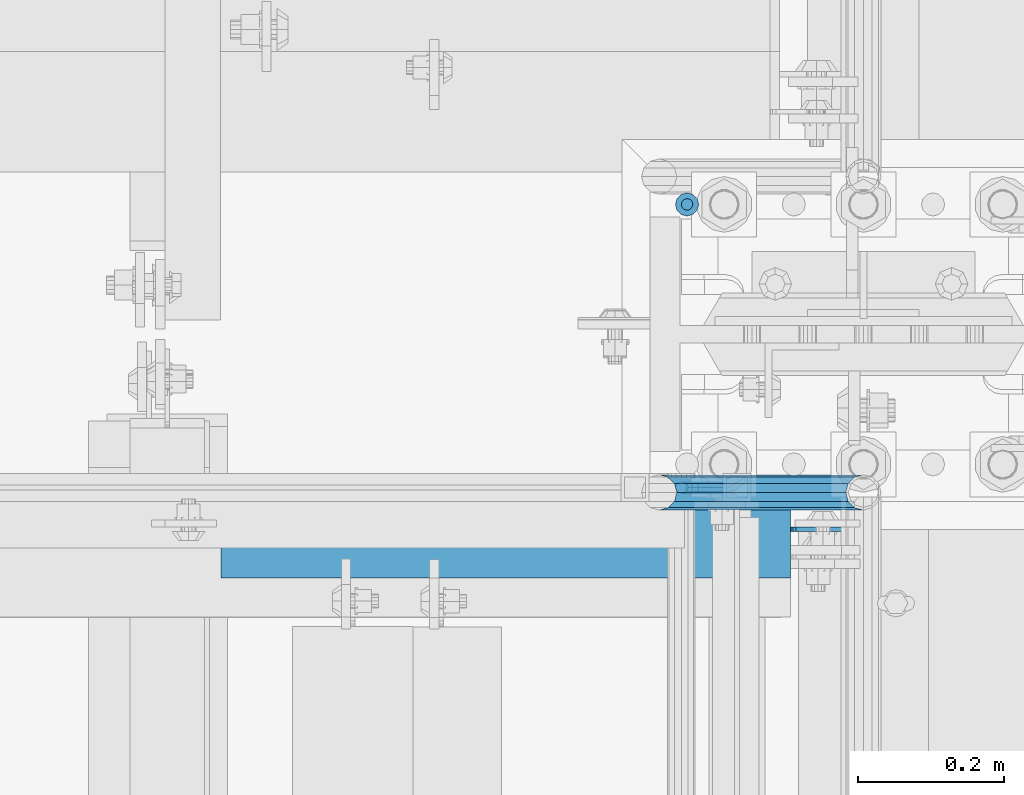
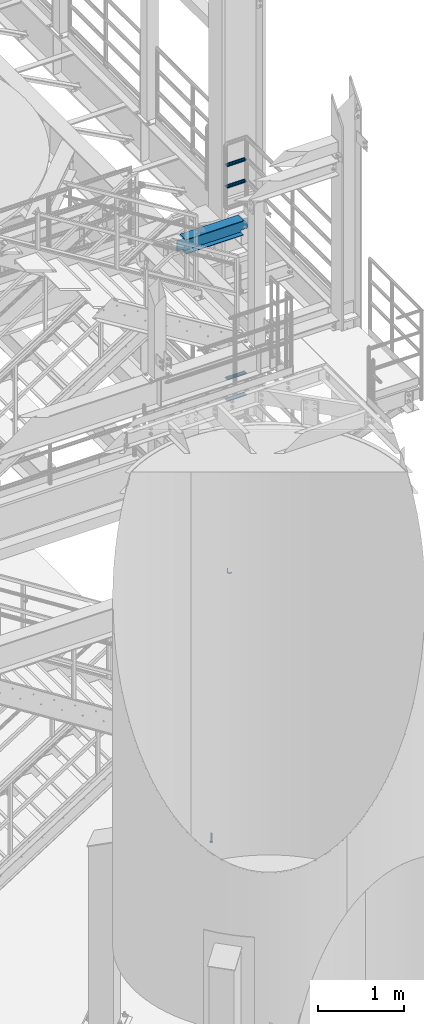
# One storey, part 1210 of 1876: 7 beams, 5 elements without a shape of their own.
"""IFC2X3 building model written with IfcOpenShell, lengths in millimetres."""

from ifc_helpers import new_model, si_unit, frame, origin_with_axes, place, context, subcontext, project, spatial, faceted_brep, material, type_object, element, aggregate, save


model = new_model("IFC2X3")

# Units and contexts
model_context = context("Model", 3, precision=1e-05, world=origin_with_axes())
body_context = subcontext(model_context, "Body", "Model", "MODEL_VIEW")
ifc_project = project(units=[si_unit("LENGTHUNIT", "METRE", prefix="MILLI"), si_unit("AREAUNIT", "SQUARE_METRE"), si_unit("VOLUMEUNIT", "CUBIC_METRE"), si_unit("MASSUNIT", "GRAM", prefix="KILO"), si_unit("TIMEUNIT", "SECOND"), si_unit("PLANEANGLEUNIT", "RADIAN"), si_unit("SOLIDANGLEUNIT", "STERADIAN"), si_unit("THERMODYNAMICTEMPERATUREUNIT", "DEGREE_CELSIUS"), si_unit("LUMINOUSINTENSITYUNIT", "LUMEN")], contexts=[model_context])

# Site, building, storey
site_placement = place(None, origin_with_axes())
site = spatial("IfcSite", under=ifc_project, at=site_placement, CompositionType="ELEMENT")
building_placement = place(site_placement, origin_with_axes())
building = spatial("IfcBuilding", under=site, at=building_placement, Name="Undefined", CompositionType="ELEMENT")
storey_placement = place(building_placement, origin_with_axes())
storey = spatial("IfcBuildingStorey", under=building, at=storey_placement, Name="Undefined", CompositionType="ELEMENT", Elevation=0.0)

# Assembly, beams
assembly_1_placement = place(storey_placement, origin_with_axes())
assembly_1 = element("IfcElementAssembly", 1, at=assembly_1_placement, inside=storey, Name="RAIL", AssemblyPlace="NOTDEFINED", PredefinedType="RIGID_FRAME")
ifc_material_1 = material()
beam_type_1 = type_object("IfcBeamType", Name="PIPE1-1/2SCH40", PredefinedType="NOTDEFINED")
beam_1_placement = place(assembly_1_placement, frame((7620.0, -4788.2175, 8620.125000036), z_axis=(0.0, 0.0, 1.0), x_axis=(-1.0, 0.0, 0.0)))
beam_1 = element("IfcBeam", 2, at=beam_1_placement, type_object=beam_type_1, material=ifc_material_1, Name="RAIL", ObjectType="PIPE1-1/2SCH40", context=body_context, shape_type="Brep", body=[
    faceted_brep([(258.502800903171, -12.0650000000005, 20.8971929933177), (258.502800903171, -12.0650000000005, 15.8661214311796), (258.009372465309, -10.2235000000001, 17.7076214311819), (255.26999389649, 0.0, 20.4470000000001), (255.26999389649, 0.0, 24.130000000001), (258.009372465309, 10.2235000000001, 17.7076214311819), (258.502800903171, 12.0650000000005, 15.8661214311796), (258.502800903171, 12.0650000000005, 20.8971929933177), (279.399993896489, 24.1299999999992, 0.0), (267.33499389649, 20.8971929933177, 12.0649999999987), (267.33499389649, 20.8971929933177, -12.0649999999987), (264.145422334351, 17.7076214311801, 10.2235000000001), (266.884800903171, 20.4470000000001, 0.0), (264.145422334351, 17.7076214311801, -10.2235000000001), (258.502800903171, 12.0650000000005, -15.8661214311796), (258.502800903171, 12.0650000000005, -20.8971929933177), (258.009372465309, 10.2235000000001, -17.7076214311819), (255.26999389649, 0.0, -20.4470000000001), (255.26999389649, 0.0, -24.130000000001), (258.502800903171, -12.0650000000005, -15.8661214311796), (258.502800903171, -12.0650000000005, -20.8971929933177), (258.009372465309, -10.2235000000001, -17.7076214311819), (279.399993896489, -24.1299999999992, 0.0), (267.33499389649, -20.8971929933177, -12.0649999999987), (267.33499389649, -20.8971929933177, 12.0649999999987), (264.145422334351, -17.7076214311801, -10.2235000000001), (266.884800903171, -20.4470000000001, 0.0), (264.145422334351, -17.7076214311801, 10.2235000000001), (12.0650000000064, -20.8971929933177, -12.0649999999987), (20.8971929933249, -12.0650000000005, -20.8971929933177), (0.0, 24.1299999999992, 0.0), (12.0650000000064, 20.8971929933177, -12.0649999999987), (12.0650000000064, 20.8971929933177, 12.0649999999987), (20.8971929933249, 12.0650000000005, 20.8971929933177), (24.1300000000064, 0.0, 24.130000000001), (20.8971929933249, 12.0650000000005, -20.8971929933177), (24.1300000000063, 0.0, -24.130000000001), (24.1300000000063, 0.0, -20.4470000000001), (20.8971929933249, -12.0650000000005, -15.8661214311796), (21.3906214311868, -10.2235000000001, -17.7076214311819), (21.3906214311868, 10.2235000000001, -17.7076214311819), (20.8971929933249, 12.0650000000005, -15.8661214311796), (15.2545715621445, 17.7076214311801, -10.2235000000001), (12.5151929933249, 20.4470000000001, 0.0), (15.2545715621445, 17.7076214311801, 10.2235000000001), (20.8971929933249, 12.0650000000005, 15.8661214311796), (21.3906214311868, 10.2235000000001, 17.7076214311819), (24.1300000000064, 0.0, 20.4470000000001), (21.3906214311868, -10.2235000000001, 17.7076214311819), (20.8971929933249, -12.0650000000005, 15.8661214311796), (20.8971929933249, -12.0650000000005, 20.8971929933177), (12.0650000000064, -20.8971929933177, 12.0649999999987), (0.0, -24.1299999999992, 0.0), (15.2545715621445, -17.7076214311801, 10.2235000000001), (12.5151929933249, -20.4470000000001, 0.0), (15.2545715621445, -17.7076214311801, -10.2235000000001)], [[[0, 1, 2, 3, 4]], [[4, 3, 5, 6, 7]], [[8, 9, 10]], [[7, 6, 11, 12, 13, 14, 15, 10, 9]], [[16, 17, 18, 15, 14]], [[19, 20, 18, 17, 21]], [[22, 23, 24]], [[24, 23, 20, 19, 25, 26, 27, 1, 0]], [[28, 29, 20, 23]], [[30, 31, 32]], [[33, 34, 4, 7]], [[32, 33, 7, 9]], [[30, 32, 9, 8]], [[31, 30, 8, 10]], [[35, 31, 10, 15]], [[36, 35, 15, 18]], [[29, 36, 18, 20]], [[37, 36, 29, 38, 39]], [[40, 41, 35, 36, 37]], [[32, 31, 35, 41, 42, 43, 44, 45, 33]], [[33, 45, 46, 47, 34]], [[34, 47, 48, 49, 50]], [[34, 50, 0, 4]], [[50, 51, 24, 0]], [[51, 52, 22, 24]], [[52, 28, 23, 22]], [[51, 28, 52]], [[50, 49, 53, 54, 55, 38, 29, 28, 51]], [[55, 54, 26, 25]], [[21, 39, 38, 55, 25, 19]], [[37, 39, 21, 17]], [[40, 37, 17, 16]], [[42, 41, 40, 16, 14, 13]], [[43, 42, 13, 12]], [[44, 43, 12, 11]], [[5, 46, 45, 44, 11, 6]], [[47, 46, 5, 3]], [[48, 47, 3, 2]], [[53, 49, 48, 2, 1, 27]], [[54, 53, 27, 26]]]),
])
beam_2_placement = place(assembly_1_placement, frame((7620.0, -4788.2175, 8924.92500003594), z_axis=(0.0, 0.0, 1.0), x_axis=(-1.0, 0.0, 0.0)))
beam_2 = element("IfcBeam", 3, at=beam_2_placement, type_object=beam_type_1, material=ifc_material_1, Name="RAIL", ObjectType="PIPE1-1/2SCH40", context=body_context, shape_type="Brep", body=[
    faceted_brep([(258.502800903171, -12.0650000000005, 20.8971929933177), (258.502800903171, -12.0650000000005, 15.8661214311796), (258.009372465309, -10.2235000000001, 17.7076214311819), (255.26999389649, 0.0, 20.4470000000001), (255.26999389649, 0.0, 24.130000000001), (258.009372465309, 10.2235000000001, 17.7076214311819), (258.502800903171, 12.0650000000005, 15.8661214311796), (258.502800903171, 12.0650000000005, 20.8971929933177), (279.399993896489, 24.1299999999992, 0.0), (267.33499389649, 20.8971929933177, 12.0649999999987), (267.33499389649, 20.8971929933177, -12.0649999999987), (264.145422334351, 17.7076214311801, 10.2235000000001), (266.884800903171, 20.4470000000001, 0.0), (264.145422334351, 17.7076214311801, -10.2235000000001), (258.502800903171, 12.0650000000005, -15.8661214311796), (258.502800903171, 12.0650000000005, -20.8971929933177), (258.009372465309, 10.2235000000001, -17.7076214311819), (255.26999389649, 0.0, -20.4470000000001), (255.26999389649, 0.0, -24.130000000001), (258.502800903171, -12.0650000000005, -15.8661214311796), (258.502800903171, -12.0650000000005, -20.8971929933177), (258.009372465309, -10.2235000000001, -17.7076214311819), (279.399993896489, -24.1299999999992, 0.0), (267.33499389649, -20.8971929933177, -12.0649999999987), (267.33499389649, -20.8971929933177, 12.0649999999987), (264.145422334351, -17.7076214311801, -10.2235000000001), (266.884800903171, -20.4470000000001, 0.0), (264.145422334351, -17.7076214311801, 10.2235000000001), (12.0650000000064, -20.8971929933177, -12.0649999999987), (20.8971929933249, -12.0650000000005, -20.8971929933177), (0.0, 24.1299999999992, 0.0), (12.0650000000064, 20.8971929933177, -12.0649999999987), (12.0650000000064, 20.8971929933177, 12.0649999999987), (20.8971929933249, 12.0650000000005, 20.8971929933177), (24.1300000000064, 0.0, 24.130000000001), (20.8971929933249, 12.0650000000005, -20.8971929933177), (24.1300000000063, 0.0, -24.130000000001), (24.1300000000063, 0.0, -20.4470000000001), (20.8971929933249, -12.0650000000005, -15.8661214311796), (21.3906214311868, -10.2235000000001, -17.7076214311819), (21.3906214311868, 10.2235000000001, -17.7076214311819), (20.8971929933249, 12.0650000000005, -15.8661214311796), (15.2545715621445, 17.7076214311801, -10.2235000000001), (12.5151929933249, 20.4470000000001, 0.0), (15.2545715621445, 17.7076214311801, 10.2235000000001), (20.8971929933249, 12.0650000000005, 15.8661214311796), (21.3906214311868, 10.2235000000001, 17.7076214311819), (24.1300000000064, 0.0, 20.4470000000001), (21.3906214311868, -10.2235000000001, 17.7076214311819), (20.8971929933249, -12.0650000000005, 15.8661214311796), (20.8971929933249, -12.0650000000005, 20.8971929933177), (12.0650000000064, -20.8971929933177, 12.0649999999987), (0.0, -24.1299999999992, 0.0), (15.2545715621445, -17.7076214311801, 10.2235000000001), (12.5151929933249, -20.4470000000001, 0.0), (15.2545715621445, -17.7076214311801, -10.2235000000001)], [[[0, 1, 2, 3, 4]], [[4, 3, 5, 6, 7]], [[8, 9, 10]], [[7, 6, 11, 12, 13, 14, 15, 10, 9]], [[16, 17, 18, 15, 14]], [[19, 20, 18, 17, 21]], [[22, 23, 24]], [[24, 23, 20, 19, 25, 26, 27, 1, 0]], [[28, 29, 20, 23]], [[30, 31, 32]], [[33, 34, 4, 7]], [[32, 33, 7, 9]], [[30, 32, 9, 8]], [[31, 30, 8, 10]], [[35, 31, 10, 15]], [[36, 35, 15, 18]], [[29, 36, 18, 20]], [[37, 36, 29, 38, 39]], [[40, 41, 35, 36, 37]], [[32, 31, 35, 41, 42, 43, 44, 45, 33]], [[33, 45, 46, 47, 34]], [[34, 47, 48, 49, 50]], [[34, 50, 0, 4]], [[50, 51, 24, 0]], [[51, 52, 22, 24]], [[52, 28, 23, 22]], [[51, 28, 52]], [[50, 49, 53, 54, 55, 38, 29, 28, 51]], [[55, 54, 26, 25]], [[21, 39, 38, 55, 25, 19]], [[37, 39, 21, 17]], [[40, 37, 17, 16]], [[42, 41, 40, 16, 14, 13]], [[43, 42, 13, 12]], [[44, 43, 12, 11]], [[5, 46, 45, 44, 11, 6]], [[47, 46, 5, 3]], [[48, 47, 3, 2]], [[53, 49, 48, 2, 1, 27]], [[54, 53, 27, 26]]]),
])
aggregate(assembly_1, [beam_1, beam_2])

assembly_2_placement = place(storey_placement, origin_with_axes())
assembly_2 = element("IfcElementAssembly", 4, at=assembly_2_placement, inside=storey, Name="RAIL", AssemblyPlace="NOTDEFINED", PredefinedType="RIGID_FRAME")
beam_3_placement = place(assembly_2_placement, frame((7620.0, -4788.2175, 5597.525000036), z_axis=(0.0, 0.0, 1.0), x_axis=(-1.0, 0.0, 0.0)))
beam_3 = element("IfcBeam", 5, at=beam_3_placement, type_object=beam_type_1, material=ifc_material_1, Name="RAIL", ObjectType="PIPE1-1/2SCH40", context=body_context, shape_type="Brep", body=[
    faceted_brep([(258.502800903171, -12.0650000000005, 20.8971929933177), (258.502800903171, -12.0650000000005, 15.8661214311796), (258.009372465309, -10.2235000000001, 17.7076214311819), (255.26999389649, 0.0, 20.4470000000001), (255.26999389649, 0.0, 24.130000000001), (258.009372465309, 10.2235000000001, 17.7076214311819), (258.502800903171, 12.0650000000005, 15.8661214311796), (258.502800903171, 12.0650000000005, 20.8971929933177), (279.399993896489, 24.1299999999992, 0.0), (267.33499389649, 20.8971929933177, 12.0649999999987), (267.33499389649, 20.8971929933177, -12.0649999999987), (264.145422334351, 17.7076214311801, 10.2235000000001), (266.884800903171, 20.4470000000001, 0.0), (264.145422334351, 17.7076214311801, -10.2235000000001), (258.502800903171, 12.0650000000005, -15.8661214311796), (258.502800903171, 12.0650000000005, -20.8971929933177), (258.009372465309, 10.2235000000001, -17.7076214311819), (255.26999389649, 0.0, -20.4470000000001), (255.26999389649, 0.0, -24.130000000001), (258.502800903171, -12.0650000000005, -15.8661214311796), (258.502800903171, -12.0650000000005, -20.8971929933177), (258.009372465309, -10.2235000000001, -17.7076214311819), (279.399993896489, -24.1299999999992, 0.0), (267.33499389649, -20.8971929933177, -12.0649999999987), (267.33499389649, -20.8971929933177, 12.0649999999987), (264.145422334351, -17.7076214311801, -10.2235000000001), (266.884800903171, -20.4470000000001, 0.0), (264.145422334351, -17.7076214311801, 10.2235000000001), (12.0650000000064, -20.8971929933177, -12.0649999999987), (20.8971929933249, -12.0650000000005, -20.8971929933177), (0.0, 24.1299999999992, 0.0), (12.0650000000064, 20.8971929933177, -12.0649999999987), (12.0650000000064, 20.8971929933177, 12.0649999999987), (20.8971929933249, 12.0650000000005, 20.8971929933177), (24.1300000000064, 0.0, 24.130000000001), (20.8971929933249, 12.0650000000005, -20.8971929933177), (24.1300000000063, 0.0, -24.130000000001), (24.1300000000063, 0.0, -20.4470000000001), (20.8971929933249, -12.0650000000005, -15.8661214311796), (21.3906214311868, -10.2235000000001, -17.7076214311819), (21.3906214311868, 10.2235000000001, -17.7076214311819), (20.8971929933249, 12.0650000000005, -15.8661214311796), (15.2545715621445, 17.7076214311801, -10.2235000000001), (12.5151929933249, 20.4470000000001, 0.0), (15.2545715621445, 17.7076214311801, 10.2235000000001), (20.8971929933249, 12.0650000000005, 15.8661214311796), (21.3906214311868, 10.2235000000001, 17.7076214311819), (24.1300000000064, 0.0, 20.4470000000001), (21.3906214311868, -10.2235000000001, 17.7076214311819), (20.8971929933249, -12.0650000000005, 15.8661214311796), (20.8971929933249, -12.0650000000005, 20.8971929933177), (12.0650000000064, -20.8971929933177, 12.0649999999987), (0.0, -24.1299999999992, 0.0), (15.2545715621445, -17.7076214311801, 10.2235000000001), (12.5151929933249, -20.4470000000001, 0.0), (15.2545715621445, -17.7076214311801, -10.2235000000001)], [[[0, 1, 2, 3, 4]], [[4, 3, 5, 6, 7]], [[8, 9, 10]], [[7, 6, 11, 12, 13, 14, 15, 10, 9]], [[16, 17, 18, 15, 14]], [[19, 20, 18, 17, 21]], [[22, 23, 24]], [[24, 23, 20, 19, 25, 26, 27, 1, 0]], [[28, 29, 20, 23]], [[30, 31, 32]], [[33, 34, 4, 7]], [[32, 33, 7, 9]], [[30, 32, 9, 8]], [[31, 30, 8, 10]], [[35, 31, 10, 15]], [[36, 35, 15, 18]], [[29, 36, 18, 20]], [[37, 36, 29, 38, 39]], [[40, 41, 35, 36, 37]], [[32, 31, 35, 41, 42, 43, 44, 45, 33]], [[33, 45, 46, 47, 34]], [[34, 47, 48, 49, 50]], [[34, 50, 0, 4]], [[50, 51, 24, 0]], [[51, 52, 22, 24]], [[52, 28, 23, 22]], [[51, 28, 52]], [[50, 49, 53, 54, 55, 38, 29, 28, 51]], [[55, 54, 26, 25]], [[21, 39, 38, 55, 25, 19]], [[37, 39, 21, 17]], [[40, 37, 17, 16]], [[42, 41, 40, 16, 14, 13]], [[43, 42, 13, 12]], [[44, 43, 12, 11]], [[5, 46, 45, 44, 11, 6]], [[47, 46, 5, 3]], [[48, 47, 3, 2]], [[53, 49, 48, 2, 1, 27]], [[54, 53, 27, 26]]]),
])
beam_4_placement = place(assembly_2_placement, frame((7620.0, -4788.2175, 5902.32500003594), z_axis=(0.0, 0.0, 1.0), x_axis=(-1.0, 0.0, 0.0)))
beam_4 = element("IfcBeam", 6, at=beam_4_placement, type_object=beam_type_1, material=ifc_material_1, Name="RAIL", ObjectType="PIPE1-1/2SCH40", context=body_context, shape_type="Brep", body=[
    faceted_brep([(258.502800903171, -12.0650000000005, 20.8971929933177), (258.502800903171, -12.0650000000005, 15.8661214311796), (258.009372465309, -10.2235000000001, 17.7076214311819), (255.26999389649, 0.0, 20.4470000000001), (255.26999389649, 0.0, 24.130000000001), (258.009372465309, 10.2235000000001, 17.7076214311819), (258.502800903171, 12.0650000000005, 15.8661214311796), (258.502800903171, 12.0650000000005, 20.8971929933177), (279.399993896489, 24.1299999999992, 0.0), (267.33499389649, 20.8971929933177, 12.0649999999987), (267.33499389649, 20.8971929933177, -12.0649999999987), (264.145422334351, 17.7076214311801, 10.2235000000001), (266.884800903171, 20.4470000000001, 0.0), (264.145422334351, 17.7076214311801, -10.2235000000001), (258.502800903171, 12.0650000000005, -15.8661214311796), (258.502800903171, 12.0650000000005, -20.8971929933177), (258.009372465309, 10.2235000000001, -17.7076214311819), (255.26999389649, 0.0, -20.4470000000001), (255.26999389649, 0.0, -24.130000000001), (258.502800903171, -12.0650000000005, -15.8661214311796), (258.502800903171, -12.0650000000005, -20.8971929933177), (258.009372465309, -10.2235000000001, -17.7076214311819), (279.399993896489, -24.1299999999992, 0.0), (267.33499389649, -20.8971929933177, -12.0649999999987), (267.33499389649, -20.8971929933177, 12.0649999999987), (264.145422334351, -17.7076214311801, -10.2235000000001), (266.884800903171, -20.4470000000001, 0.0), (264.145422334351, -17.7076214311801, 10.2235000000001), (12.0650000000064, -20.8971929933177, -12.0649999999987), (20.8971929933249, -12.0650000000005, -20.8971929933177), (0.0, 24.1299999999992, 0.0), (12.0650000000064, 20.8971929933177, -12.0649999999987), (12.0650000000064, 20.8971929933177, 12.0649999999987), (20.8971929933249, 12.0650000000005, 20.8971929933177), (24.1300000000064, 0.0, 24.130000000001), (20.8971929933249, 12.0650000000005, -20.8971929933177), (24.1300000000063, 0.0, -24.130000000001), (24.1300000000063, 0.0, -20.4470000000001), (20.8971929933249, -12.0650000000005, -15.8661214311796), (21.3906214311868, -10.2235000000001, -17.7076214311819), (21.3906214311868, 10.2235000000001, -17.7076214311819), (20.8971929933249, 12.0650000000005, -15.8661214311796), (15.2545715621445, 17.7076214311801, -10.2235000000001), (12.5151929933249, 20.4470000000001, 0.0), (15.2545715621445, 17.7076214311801, 10.2235000000001), (20.8971929933249, 12.0650000000005, 15.8661214311796), (21.3906214311868, 10.2235000000001, 17.7076214311819), (24.1300000000064, 0.0, 20.4470000000001), (21.3906214311868, -10.2235000000001, 17.7076214311819), (20.8971929933249, -12.0650000000005, 15.8661214311796), (20.8971929933249, -12.0650000000005, 20.8971929933177), (12.0650000000064, -20.8971929933177, 12.0649999999987), (0.0, -24.1299999999992, 0.0), (15.2545715621445, -17.7076214311801, 10.2235000000001), (12.5151929933249, -20.4470000000001, 0.0), (15.2545715621445, -17.7076214311801, -10.2235000000001)], [[[0, 1, 2, 3, 4]], [[4, 3, 5, 6, 7]], [[8, 9, 10]], [[7, 6, 11, 12, 13, 14, 15, 10, 9]], [[16, 17, 18, 15, 14]], [[19, 20, 18, 17, 21]], [[22, 23, 24]], [[24, 23, 20, 19, 25, 26, 27, 1, 0]], [[28, 29, 20, 23]], [[30, 31, 32]], [[33, 34, 4, 7]], [[32, 33, 7, 9]], [[30, 32, 9, 8]], [[31, 30, 8, 10]], [[35, 31, 10, 15]], [[36, 35, 15, 18]], [[29, 36, 18, 20]], [[37, 36, 29, 38, 39]], [[40, 41, 35, 36, 37]], [[32, 31, 35, 41, 42, 43, 44, 45, 33]], [[33, 45, 46, 47, 34]], [[34, 47, 48, 49, 50]], [[34, 50, 0, 4]], [[50, 51, 24, 0]], [[51, 52, 22, 24]], [[52, 28, 23, 22]], [[51, 28, 52]], [[50, 49, 53, 54, 55, 38, 29, 28, 51]], [[55, 54, 26, 25]], [[21, 39, 38, 55, 25, 19]], [[37, 39, 21, 17]], [[40, 37, 17, 16]], [[42, 41, 40, 16, 14, 13]], [[43, 42, 13, 12]], [[44, 43, 12, 11]], [[5, 46, 45, 44, 11, 6]], [[47, 46, 5, 3]], [[48, 47, 3, 2]], [[53, 49, 48, 2, 1, 27]], [[54, 53, 27, 26]]]),
])
aggregate(assembly_2, [beam_3, beam_4])

# Assembly, beam
assembly_3_placement = place(storey_placement, origin_with_axes())
assembly_3 = element("IfcElementAssembly", 7, at=assembly_3_placement, inside=storey, Name="RAIL", AssemblyPlace="NOTDEFINED", PredefinedType="RIGID_FRAME")
ifc_material_2 = material(Name="STEEL/A36")
beam_type_2 = type_object("IfcBeamType", PredefinedType="NOTDEFINED")
beam_5_placement = place(assembly_3_placement, frame((7427.912500765, -4781.55000037342, 3123.43417460616), z_axis=(0.0, 1.0, 0.0), x_axis=(-1.0, 0.0, 0.0)))
beam_5 = element("IfcBeam", 8, at=beam_5_placement, type_object=beam_type_2, material=ifc_material_2, Name="BRACKET", context=body_context, shape_type="Brep", body=[
    faceted_brep([(0.0, -7.9375, 0.0), (0.0, -5.61266007566822, -5.61266007566883), (23.8125, -5.61266007566883, -5.61266007566792), (23.8125, -7.9375, 0.0), (0.0, 0.0, -7.9375), (23.8125, 0.0, -7.9375), (0.0, 5.61266007566822, -5.61266007566883), (23.8125, 5.61266007566883, -5.61266007566792), (0.0, 7.9375, 0.0), (23.8125, 7.9375, 0.0), (0.0, 5.61266007566822, 5.61266007566883), (23.8125, 5.61266007566883, 5.61266007566792), (0.0, 0.0, 7.9375), (23.8125, 0.0, 7.9375), (0.0, -5.61266007566822, 5.61266007566883), (23.8125, -5.61266007566883, 5.61266007566792), (39.6077592547981, -4.79562758825341, 0.0), (38.7180815328556, -2.64775556579843, 5.61266007566792), (36.5702095103998, 2.53766620105671, 7.9375), (34.4223374879448, 7.72308796790821, 5.61266007566792), (33.5326597660023, 9.87095999036319, 0.0), (34.4223374879448, 7.72308796790821, -5.61266007566792), (36.5702095103998, 2.53766620105671, -7.9375), (38.7180815328556, -2.64775556579843, -5.61266007566792), (51.3544233967659, 5.79557812911298, -5.61266007566792), (52.9983334724348, 4.15166805344415, 0.0), (47.3856733967659, 9.76432812911298, -7.9375), (43.4169233967659, 13.733078129113, -5.61266007566792), (41.773013321098, 15.3769882047818, 0.0), (43.4169233967659, 13.733078129113, 5.61266007566792), (47.3856733967659, 9.76432812911298, 7.9375), (51.3544233967659, 5.79557812911298, 5.61266007566792), (59.7977570916764, 18.4319199930251, -5.61266007566792), (61.9456291141314, 17.5422422710835, 0.0), (54.6123353248231, 20.5797920154801, -7.9375), (49.4269135579698, 22.727664037935, -5.61266007566792), (47.2790415355148, 23.6173417598766, 0.0), (49.4269135579698, 22.727664037935, 5.61266007566792), (54.6123353248231, 20.5797920154801, 7.9375), (59.7977570916764, 18.4319199930251, 5.61266007566792), (62.7626616015468, 33.3375015258789, -5.61266007566792), (65.0875015258789, 33.3375015258789, 0.0), (57.1500015258789, 33.3375015258789, -7.9375), (51.5373414502101, 33.3375015258789, -5.61266007566792), (49.2125015258789, 33.3375015258789, 0.0), (51.5373414502101, 33.3375015258789, 5.61266007566792), (57.1500015258789, 33.3375015258789, 7.9375), (62.7626616015468, 33.3375015258789, 5.61266007566792), (62.7626616015468, 76.1999969482422, -5.61266007566792), (65.0875015258789, 76.1999969482422, 0.0), (57.1500015258789, 76.1999969482422, -7.9375), (51.537341450211, 76.1999969482422, -5.61266007566792), (49.2125015258789, 76.1999969482422, 0.0), (51.537341450211, 76.1999969482422, 5.61266007566792), (57.1500015258789, 76.1999969482422, 7.9375), (62.7626616015468, 76.1999969482422, 5.61266007566792)], [[[0, 1, 2, 3]], [[1, 4, 5, 2]], [[4, 6, 7, 5]], [[6, 8, 9, 7]], [[8, 10, 11, 9]], [[10, 12, 13, 11]], [[12, 14, 15, 13]], [[14, 0, 3, 15]], [[14, 12, 10, 8, 6, 4, 1, 0]], [[15, 3, 16, 17]], [[13, 15, 17, 18]], [[11, 13, 18, 19]], [[9, 11, 19, 20]], [[7, 9, 20, 21]], [[5, 7, 21, 22]], [[2, 5, 22, 23]], [[3, 2, 23, 16]], [[23, 24, 25, 16]], [[22, 26, 24, 23]], [[21, 27, 26, 22]], [[20, 28, 27, 21]], [[19, 29, 28, 20]], [[18, 30, 29, 19]], [[17, 31, 30, 18]], [[16, 25, 31, 17]], [[24, 32, 33, 25]], [[26, 34, 32, 24]], [[27, 35, 34, 26]], [[28, 36, 35, 27]], [[29, 37, 36, 28]], [[30, 38, 37, 29]], [[31, 39, 38, 30]], [[25, 33, 39, 31]], [[32, 40, 41, 33]], [[34, 42, 40, 32]], [[35, 43, 42, 34]], [[36, 44, 43, 35]], [[37, 45, 44, 36]], [[38, 46, 45, 37]], [[39, 47, 46, 38]], [[33, 41, 47, 39]], [[41, 40, 48, 49]], [[40, 42, 50, 48]], [[42, 43, 51, 50]], [[43, 44, 52, 51]], [[44, 45, 53, 52]], [[45, 46, 54, 53]], [[46, 47, 55, 54]], [[47, 41, 49, 55]], [[50, 51, 52, 53, 54, 55, 49, 48]]]),
])
aggregate(assembly_3, [beam_5])

assembly_4_placement = place(storey_placement, origin_with_axes())
assembly_4 = element("IfcElementAssembly", 9, at=assembly_4_placement, inside=storey, Name="BEAM", AssemblyPlace="NOTDEFINED", PredefinedType="RIGID_FRAME")
ifc_material_3 = material(Name="STEEL/A992")
beam_type_3 = type_object("IfcBeamType", Name="W8X18", PredefinedType="NOTDEFINED")
beam_6_placement = place(assembly_4_placement, frame((6642.496875, -4838.70000113111, 8050.2125), z_axis=(0.0, 0.0, 1.0), x_axis=(1.0, 0.0, 0.0)))
beam_6 = element("IfcBeam", 10, at=beam_6_placement, type_object=beam_type_3, material=ifc_material_3, Name="BEAM", ObjectType="W8X18", context=body_context, shape_type="Brep", body=[
    faceted_brep([(871.140625, -3.17500000000018, -95.25), (871.140625, -66.6750000000002, -95.25), (871.140625, -66.6750000000002, -103.1875), (871.140625, 66.6750000000002, -103.1875), (871.140625, 66.6750000000002, -95.25), (871.140625, 3.17500000000018, -95.25), (871.140625, 3.17500000000018, -84.1374998092642), (871.140625, -3.17500000000018, -84.1374998092642), (872.107354922588, 3.17500000000018, -79.2774202912187), (872.107354922588, -3.17500000000018, -79.2774202912187), (874.860368823066, 3.17500000000018, -75.1572438230651), (874.860368823066, -3.17500000000018, -75.1572438230651), (878.98054529122, 3.17500000000018, -72.4042299225866), (878.98054529122, -3.17500000000018, -72.4042299225866), (883.840624809265, 3.17500000000018, -71.4374999999991), (883.840624809265, -3.17500000000018, -71.4374999999991), (960.040625000001, -3.17500000000018, -71.4374999999991), (960.040625000001, 3.17500000000018, -71.4374999999991), (98.4250000000011, 3.17500000000018, 95.25), (98.4250000000011, 66.6750000000002, 95.25), (877.490624999999, 66.6750000000002, 95.25), (877.490624999999, 3.17500000000018, 95.25), (104.775000000001, -3.17500000000018, -84.1374998092642), (104.775000000001, 3.17500000000018, -84.1374998092642), (104.775000000001, 3.17500000000018, -95.25), (104.775000000001, 66.6750000000002, -95.25), (104.775000000001, 66.6750000000002, -103.1875), (104.775000000001, -66.6750000000002, -103.1875), (104.775000000001, -66.6750000000002, -95.25), (104.775000000001, -3.17500000000018, -95.25), (103.808270077413, -3.17500000000018, -79.2774202912187), (103.808270077413, 3.17500000000018, -79.2774202912187), (101.055256176935, -3.17500000000018, -75.1572438230651), (101.055256176935, 3.17500000000018, -75.1572438230651), (96.9350797087809, -3.17500000000018, -72.4042299225866), (96.9350797087809, 3.17500000000018, -72.4042299225866), (92.0750001907354, -3.17500000000018, -71.4374999999991), (92.0750001907354, 3.17500000000018, -71.4374999999991), (15.8750000000009, -3.17500000000018, -71.4374999999991), (15.8750000000009, 3.17500000000018, -71.4374999999991), (15.875, -3.17500000000018, 77.7874999999949), (15.875, 3.17500000000018, 77.7874999999949), (85.725000190736, -3.17500000000018, 77.7875000000013), (85.725000190736, 3.17500000000018, 77.7875000000013), (90.5850797087814, -3.17500000000018, 78.7542299225888), (90.5850797087814, 3.17500000000018, 78.7542299225888), (94.7052561769351, -3.17500000000018, 81.5072438230673), (94.7052561769351, 3.17500000000018, 81.5072438230673), (97.4582700774135, -3.17500000000018, 85.6274202912209), (97.4582700774135, 3.17500000000018, 85.6274202912209), (98.4250000000011, -3.17500000000018, 90.4874998092664), (98.4250000000011, 3.17500000000018, 90.4874998092664), (98.4250000000011, -66.6750000000002, 103.1875), (98.4250000000011, 66.6750000000002, 103.1875), (98.4250000000011, -3.17500000000018, 95.25), (98.4250000000011, -66.6750000000002, 95.25), (877.490624999999, -3.17500000000018, 95.25), (877.490624999999, -66.6750000000002, 95.25), (877.490624999999, -66.6750000000002, 103.1875), (877.490624999999, 66.6750000000002, 103.1875), (877.490624999999, -3.17500000000018, 90.4874998092664), (877.490624999999, 3.17500000000018, 90.4874998092664), (878.457354922587, -3.17500000000018, 85.6274202912209), (878.457354922587, 3.17500000000018, 85.6274202912209), (881.210368823065, -3.17500000000018, 81.5072438230673), (881.210368823065, 3.17500000000018, 81.5072438230673), (885.330545291219, -3.17500000000018, 78.7542299225888), (885.330545291219, 3.17500000000018, 78.7542299225888), (890.190624809265, -3.17500000000018, 77.7875000000013), (890.190624809265, 3.17500000000018, 77.7875000000013), (960.040625000001, -3.17500000000018, 77.7875000000013), (960.040625000001, 3.17500000000018, 77.7875000000013)], [[[0, 1, 2, 3, 4, 5, 6, 7]], [[7, 6, 8, 9]], [[9, 8, 10, 11]], [[11, 10, 12, 13]], [[13, 12, 14, 15]], [[16, 15, 14, 17]], [[18, 19, 20, 21]], [[22, 23, 24, 25, 26, 27, 28, 29]], [[30, 31, 23, 22]], [[32, 33, 31, 30]], [[34, 35, 33, 32]], [[36, 37, 35, 34]], [[38, 39, 37, 36]], [[40, 41, 39, 38]], [[42, 43, 41, 40]], [[44, 45, 43, 42]], [[46, 47, 45, 44]], [[48, 49, 47, 46]], [[50, 51, 49, 48]], [[52, 53, 19, 18, 51, 50, 54, 55]], [[55, 54, 56, 57]], [[52, 55, 57, 58]], [[53, 52, 58, 59]], [[19, 53, 59, 20]], [[58, 57, 56, 60, 61, 21, 20, 59]], [[62, 63, 61, 60]], [[64, 65, 63, 62]], [[66, 67, 65, 64]], [[68, 69, 67, 66]], [[70, 71, 69, 68]], [[71, 70, 16, 17]], [[12, 10, 8, 6, 5, 24, 23, 31, 33, 35, 37, 39, 41, 43, 45, 47, 49, 51, 18, 21, 61, 63, 65, 67, 69, 71, 17, 14]], [[25, 24, 5, 4]], [[26, 25, 4, 3]], [[27, 26, 3, 2]], [[28, 27, 2, 1]], [[29, 28, 1, 0]], [[70, 68, 66, 64, 62, 60, 56, 54, 50, 48, 46, 44, 42, 40, 38, 36, 34, 32, 30, 22, 29, 0, 7, 9, 11, 13, 15, 16]]]),
])
aggregate(assembly_4, [beam_6])

assembly_5_placement = place(storey_placement, origin_with_axes())
assembly_5 = element("IfcElementAssembly", 11, at=assembly_5_placement, inside=storey, Name="TEMPLATE", AssemblyPlace="NOTDEFINED", PredefinedType="RIGID_FRAME")
ifc_material_4 = material(Name="STEEL/A108")
beam_type_4 = type_object("IfcBeamType", Name="5/8-DIA_HEADED ANCHOR STUD", PredefinedType="NOTDEFINED")
beam_7_placement = place(assembly_5_placement, frame((7378.7, -4394.2, -787.4), z_axis=(1.0, 0.0, 0.0), x_axis=(0.0, 0.0, -1.0)))
beam_7 = element("IfcBeam", 12, at=beam_7_placement, type_object=beam_type_4, material=ifc_material_4, Name="HEADED ANCHOR STUD", ObjectType="5/8-DIA_HEADED ANCHOR STUD", context=body_context, shape_type="Brep", body=[
    faceted_brep([(0.0, -7.94000005722046, 0.0), (0.0, -6.86999988555908, -3.97000002861023), (116.84, -6.86999988555908, -3.97000002861023), (116.84, -7.94000005722046, 0.0), (0.0, -3.97000002861023, -6.86999988555908), (116.84, -3.97000002861023, -6.86999988555908), (0.0, 0.0, -7.94000005722046), (116.84, 0.0, -7.94000005722046), (0.0, 3.97000002861023, -6.86999988555908), (116.84, 3.97000002861023, -6.86999988555908), (0.0, 6.86999988555908, -3.97000002861023), (116.84, 6.86999988555908, -3.97000002861023), (0.0, 7.94000005722046, 0.0), (116.84, 7.94000005722046, 0.0), (0.0, 6.86999988555908, 3.97000002861023), (116.84, 6.86999988555908, 3.97000002861023), (0.0, 3.97000002861023, 6.86999988555908), (116.84, 3.97000002861023, 6.86999988555908), (0.0, 0.0, 7.94000005722046), (116.84, 0.0, 7.94000005722046), (0.0, -3.97000002861023, 6.86999988555908), (116.84, -3.97000002861023, 6.86999988555908), (0.0, -6.86999988555908, 3.97000002861023), (116.84, -6.86999988555908, 3.97000002861023), (118.11, -13.75, -7.94000005722046), (118.11, -15.8800001144409, 0.0), (118.11, -7.94000005722046, -13.75), (118.11, 0.0, -15.8800001144409), (118.11, 7.94000005722046, -13.75), (118.11, 13.75, -7.94000005722046), (118.11, 15.8800001144409, 0.0), (118.11, 13.75, 7.94000005722046), (118.11, 7.94000005722046, 13.75), (118.11, 0.0, 15.8800001144409), (118.11, -7.94000005722046, 13.75), (118.11, -13.75, 7.94000005722046), (127.0, -13.75, -7.94000005722046), (127.0, -15.8800001144409, 0.0), (127.0, -7.94000005722046, -13.75), (127.0, 0.0, -15.8800001144409), (127.0, 7.94000005722046, -13.75), (127.0, 13.75, -7.94000005722046), (127.0, 15.8800001144409, 0.0), (127.0, 13.75, 7.94000005722046), (127.0, 7.94000005722046, 13.75), (127.0, 0.0, 15.8800001144409), (127.0, -7.94000005722046, 13.75), (127.0, -13.75, 7.94000005722046)], [[[0, 1, 2, 3]], [[1, 4, 5, 2]], [[4, 6, 7, 5]], [[6, 8, 9, 7]], [[8, 10, 11, 9]], [[10, 12, 13, 11]], [[12, 14, 15, 13]], [[14, 16, 17, 15]], [[16, 18, 19, 17]], [[18, 20, 21, 19]], [[20, 22, 23, 21]], [[22, 0, 3, 23]], [[22, 20, 18, 16, 14, 12, 10, 8, 6, 4, 1, 0]], [[3, 2, 24, 25]], [[2, 5, 26, 24]], [[5, 7, 27, 26]], [[7, 9, 28, 27]], [[9, 11, 29, 28]], [[11, 13, 30, 29]], [[13, 15, 31, 30]], [[15, 17, 32, 31]], [[17, 19, 33, 32]], [[19, 21, 34, 33]], [[21, 23, 35, 34]], [[23, 3, 25, 35]], [[25, 24, 36, 37]], [[24, 26, 38, 36]], [[26, 27, 39, 38]], [[27, 28, 40, 39]], [[28, 29, 41, 40]], [[29, 30, 42, 41]], [[30, 31, 43, 42]], [[31, 32, 44, 43]], [[32, 33, 45, 44]], [[33, 34, 46, 45]], [[34, 35, 47, 46]], [[35, 25, 37, 47]], [[38, 39, 40, 41, 42, 43, 44, 45, 46, 47, 37, 36]]]),
])
aggregate(assembly_5, [beam_7])

save(model, "model.ifc")
